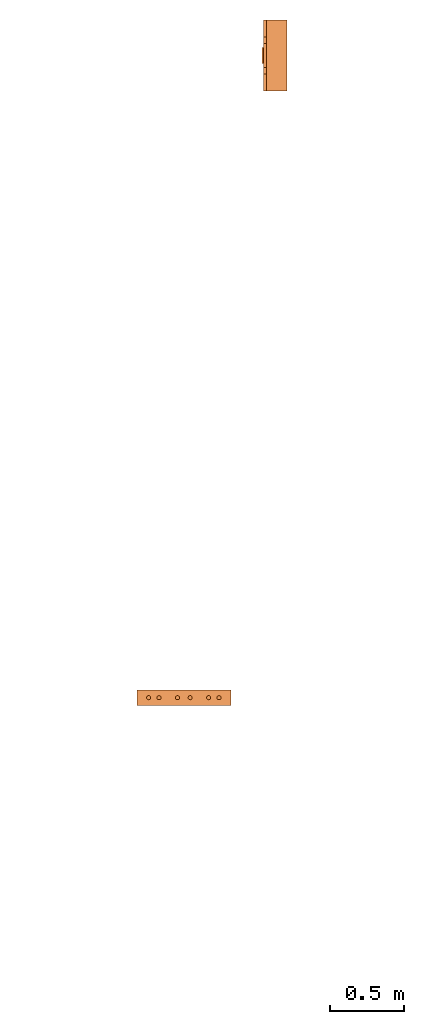
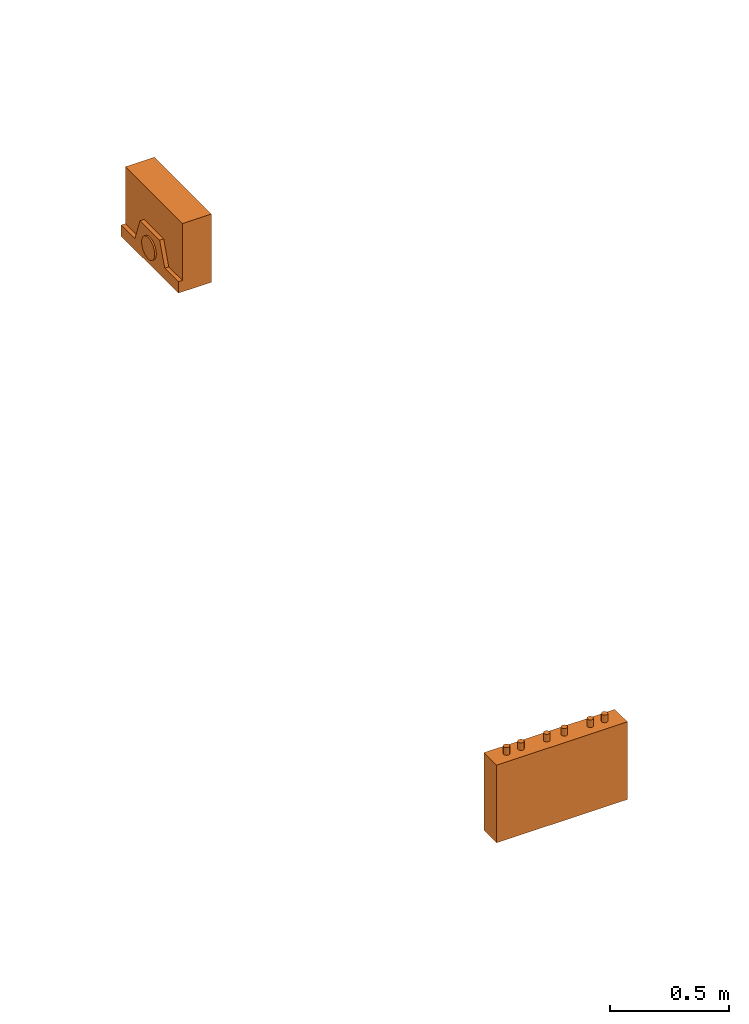
# One storey, part 3 of 4: 2 proxies.
"""IFC2X3 building model written with IfcOpenShell, lengths in millimetres."""

from ifc_helpers import new_model, entity, si_unit, converted_unit, derived_unit, direction, frame, origin, place, context, subcontext, project, spatial, faceted_brep, source, transform, mapped, material, material_list, type_object, type_shapes, element, save


model = new_model("IFC2X3")

# Units and contexts
model_context = context("Model", 3, precision=0.01, world=origin(), true_north=direction((6.12303176911189e-17, 1.0)))
body_context = subcontext(model_context, "Body", "Model", "MODEL_VIEW")
ifc_project = project(units=[si_unit("LENGTHUNIT", "METRE", prefix="MILLI"), si_unit("AREAUNIT", "SQUARE_METRE"), si_unit("VOLUMEUNIT", "CUBIC_METRE"), converted_unit("PLANEANGLEUNIT", "DEGREE", entity("IfcRatioMeasure", 0.0174532925199433), si_unit("PLANEANGLEUNIT", "RADIAN"), dimensions=[0, 0, 0, 0, 0, 0, 0]), si_unit("MASSUNIT", "GRAM", prefix="KILO"), derived_unit("MASSDENSITYUNIT", [(si_unit("MASSUNIT", "GRAM", prefix="KILO"), 1), (si_unit("LENGTHUNIT", "METRE"), -3)]), derived_unit("MOMENTOFINERTIAUNIT", [(si_unit("LENGTHUNIT", "METRE"), 4)]), si_unit("TIMEUNIT", "SECOND"), si_unit("FREQUENCYUNIT", "HERTZ"), si_unit("THERMODYNAMICTEMPERATUREUNIT", "DEGREE_CELSIUS"), derived_unit("THERMALTRANSMITTANCEUNIT", [(si_unit("MASSUNIT", "GRAM", prefix="KILO"), 1), (si_unit("THERMODYNAMICTEMPERATUREUNIT", "KELVIN"), -1), (si_unit("TIMEUNIT", "SECOND"), -3)]), derived_unit("VOLUMETRICFLOWRATEUNIT", [(si_unit("LENGTHUNIT", "METRE"), 3), (si_unit("TIMEUNIT", "SECOND"), -1)]), derived_unit("MASSFLOWRATEUNIT", [(si_unit("MASSUNIT", "GRAM", prefix="KILO"), 1), (si_unit("TIMEUNIT", "SECOND"), -1)]), derived_unit("ROTATIONALFREQUENCYUNIT", [(si_unit("TIMEUNIT", "SECOND"), -1)]), si_unit("ELECTRICCURRENTUNIT", "AMPERE"), si_unit("ELECTRICVOLTAGEUNIT", "VOLT"), si_unit("POWERUNIT", "WATT"), si_unit("FORCEUNIT", "NEWTON", prefix="KILO"), si_unit("ILLUMINANCEUNIT", "LUX"), si_unit("LUMINOUSFLUXUNIT", "LUMEN"), si_unit("LUMINOUSINTENSITYUNIT", "CANDELA"), derived_unit("USERDEFINED", [(si_unit("MASSUNIT", "GRAM", prefix="KILO"), -1), (si_unit("LENGTHUNIT", "METRE"), -2), (si_unit("TIMEUNIT", "SECOND"), 3), (si_unit("LUMINOUSFLUXUNIT", "LUMEN"), 1)]), derived_unit("LINEARVELOCITYUNIT", [(si_unit("LENGTHUNIT", "METRE"), 1), (si_unit("TIMEUNIT", "SECOND"), -1)]), si_unit("PRESSUREUNIT", "PASCAL"), derived_unit("USERDEFINED", [(si_unit("LENGTHUNIT", "METRE"), -2), (si_unit("MASSUNIT", "GRAM", prefix="KILO"), 1), (si_unit("TIMEUNIT", "SECOND"), -2)]), derived_unit("LINEARFORCEUNIT", [(si_unit("MASSUNIT", "GRAM", prefix="KILO"), 1), (si_unit("LENGTHUNIT", "METRE"), 1), (si_unit("TIMEUNIT", "SECOND"), -2), (si_unit("LENGTHUNIT", "METRE"), -1)]), derived_unit("PLANARFORCEUNIT", [(si_unit("MASSUNIT", "GRAM", prefix="KILO"), 1), (si_unit("LENGTHUNIT", "METRE"), 1), (si_unit("TIMEUNIT", "SECOND"), -2), (si_unit("LENGTHUNIT", "METRE"), -2)])], contexts=[model_context])

# Site, building, storey
site_placement = place(None, frame((0.0, 2493.83037508239, 0.0)))
site = spatial("IfcSite", under=ifc_project, at=site_placement, CompositionType="ELEMENT")
building_placement = place(site_placement, origin())
building = spatial("IfcBuilding", under=site, at=building_placement, CompositionType="ELEMENT")
storey_placement = place(building_placement, frame((0.0, 0.0, 15900.0)))
storey = spatial("IfcBuildingStorey", under=building, at=storey_placement, Name="05", CompositionType="ELEMENT", Elevation=15900.0)

# Proxies
ifc_material_1 = material()
ifc_material_2 = material()
ifc_material_list_1 = material_list([ifc_material_1, ifc_material_2])
building_element_proxy_type_1 = type_object("IfcBuildingElementProxyType", PredefinedType="NOTDEFINED", material=ifc_material_1)
shared_shape_1 = source(origin(), body_context, "Body", "Brep", [
    faceted_brep([(168.201612490282, 212.500000000001, 135.54049916809), (168.201612490282, 201.109127034741, 126.799974925206), (168.201612490282, 192.368602791857, 115.409101959946), (168.201612490282, 186.874079554102, 102.144149440585), (168.201612490282, 185.0, 87.9091019599461), (168.201612490282, 186.874079554102, 73.6740544793074), (168.201612490282, 192.368602791856, 60.4091019599461), (168.201612490282, 201.10912703474, 49.0182289946861), (168.201612490282, 212.500000000001, 40.2777047518019), (168.201612490282, 225.764952519362, 34.7831815140474), (168.201612490282, 240.0, 32.9091019599461), (168.201612490282, 254.235047480639, 34.7831815140472), (168.201612490282, 267.5, 40.2777047518019), (168.201612490282, 278.890872965261, 49.0182289946858), (168.201612490282, 287.631397208145, 60.4091019599458), (168.201612490282, 293.125920445899, 73.6740544793071), (168.201612490282, 295.0, 87.9091019599458), (168.201612490282, 293.125920445899, 102.144149440584), (168.201612490282, 287.631397208145, 115.409101959946), (168.201612490282, 278.890872965261, 126.799974925206), (168.201612490282, 267.500000000001, 135.54049916809), (168.201612490282, 254.235047480639, 141.035022405845), (168.201612490282, 240.0, 142.909101959946), (168.201612490282, 225.764952519362, 141.035022405845), (160.0, 225.764952519362, 34.7831815140474), (160.0, 212.500000000001, 40.2777047518019), (160.0, 201.10912703474, 49.0182289946861), (160.0, 192.368602791856, 60.4091019599461), (160.0, 186.874079554102, 73.6740544793074), (160.0, 185.0, 87.9091019599463), (160.0, 186.874079554102, 102.144149440585), (160.0, 192.368602791857, 115.409101959946), (160.0, 201.109127034741, 126.799974925206), (160.0, 212.500000000001, 135.54049916809), (160.0, 225.764952519362, 141.035022405845), (160.0, 240.0, 142.909101959946), (160.0, 254.235047480639, 141.035022405845), (160.0, 267.500000000001, 135.54049916809), (160.0, 278.890872965261, 126.799974925206), (160.0, 287.631397208145, 115.409101959946), (160.0, 293.125920445899, 102.144149440584), (160.0, 295.0, 87.9091019599458), (160.0, 293.125920445899, 73.6740544793071), (160.0, 287.631397208145, 60.4091019599458), (160.0, 278.890872965261, 49.0182289946858), (160.0, 267.5, 40.2777047518019), (160.0, 254.235047480639, 34.7831815140472), (160.0, 240.0, 32.9091019599461)], [[[0, 1, 2, 3, 4, 5, 6, 7, 8, 9, 10, 11, 12, 13, 14, 15, 16, 17, 18, 19, 20, 21, 22, 23]], [[24, 25, 26, 27, 28, 29, 30, 31, 32, 33, 34, 35, 36, 37, 38, 39, 40, 41, 42, 43, 44, 45, 46, 47]], [[40, 17, 16, 41]], [[39, 18, 17, 40]], [[20, 19, 38, 37]], [[39, 38, 19, 18]], [[21, 20, 37, 36]], [[22, 21, 36, 35]], [[34, 23, 22, 35]], [[33, 0, 23, 34]], [[2, 1, 32, 31]], [[33, 32, 1, 0]], [[3, 2, 31, 30]], [[4, 3, 30, 29]], [[28, 5, 4, 29]], [[27, 6, 5, 28]], [[8, 7, 26, 25]], [[27, 26, 7, 6]], [[9, 8, 25, 24]], [[10, 9, 24, 47]], [[46, 11, 10, 47]], [[45, 12, 11, 46]], [[14, 13, 44, 43]], [[45, 44, 13, 12]], [[15, 14, 43, 42]], [[16, 15, 42, 41]]]),
    faceted_brep([(160.0, 0.0, 0.0), (160.0, 480.0, 0.0), (160.0, 480.0, 58.2870579365997), (160.0, 365.0, 58.2870579366005), (160.0, 322.247482084292, 175.748635534839), (160.0, 157.75251791571, 175.748635534839), (160.0, 115.0, 58.2870579366), (160.0, 0.0, 58.2870579365997), (0.0, 480.0, 0.0), (0.0, 0.0, 0.0), (0.0, 0.0, 350.0), (0.0, 480.0, 350.0), (140.211167148102, 480.0, 350.0), (140.211167148102, 480.0, 58.2870579365997), (140.211167148102, 0.0, 350.0), (140.211167148102, 0.0, 58.2870579365997), (140.211167148102, 365.0, 58.2870579366), (140.211167148102, 115.0, 58.2870579366), (140.211167148102, 157.75251791571, 175.748635534839), (140.211167148102, 322.247482084292, 175.748635534839)], [[[0, 1, 2, 3, 4, 5, 6, 7]], [[8, 9, 10, 11]], [[8, 11, 12, 13, 2, 1]], [[11, 10, 14, 12]], [[10, 9, 0, 7, 15, 14]], [[1, 0, 9, 8]], [[16, 13, 12, 14, 15, 17, 18, 19]], [[13, 16, 3, 2]], [[17, 15, 7, 6]], [[18, 17, 6, 5]], [[19, 18, 5, 4]], [[16, 19, 4, 3]]]),
])
type_shapes(building_element_proxy_type_1, [shared_shape_1])
proxy_1_placement = place(storey_placement, frame((60320.108534949, 16006.7429169829, 1500.0), z_axis=(0.0, 0.0, 1.0), x_axis=(-1.0, 0.0, 0.0)))
element("IfcBuildingElementProxy", 1, at=proxy_1_placement, inside=storey, type_object=building_element_proxy_type_1, material=ifc_material_list_1, context=body_context, shape_type="MappedRepresentation", body=[
    mapped(shared_shape_1, transform((0.0, 0.0, 0.0), scale=1.0)),
])
ifc_material_3 = material()
ifc_material_list_2 = material_list([ifc_material_3, ifc_material_2])
building_element_proxy_type_2 = type_object("IfcBuildingElementProxyType", PredefinedType="NOTDEFINED", material=ifc_material_3)
shared_shape_2 = source(origin(), body_context, "Body", "Brep", [
    faceted_brep([(61.7366777047886, 89.258069163288, 398.0), (63.9615384211591, 86.3585742266764, 398.0), (65.3601443362239, 82.9820408581116, 398.0), (65.837182768177, 79.3585742266763, 398.0), (65.3601443362239, 75.735107595241, 398.0), (63.9615384211591, 72.3585742266763, 398.0), (61.7366777047886, 69.4590792900646, 398.0), (58.8371827681769, 67.2342185736942, 398.0), (55.4606493996122, 65.8356126586294, 398.0), (51.8371827681769, 65.3585742266764, 398.0), (48.2137161367416, 65.8356126586295, 398.0), (44.8371827681769, 67.2342185736943, 398.0), (41.9376878315653, 69.4590792900647, 398.0), (39.7128271151948, 72.3585742266764, 398.0), (38.31422120013, 75.7351075952411, 398.0), (37.837182768177, 79.3585742266764, 398.0), (38.31422120013, 82.9820408581117, 398.0), (39.7128271151949, 86.3585742266764, 398.0), (41.9376878315653, 89.258069163288, 398.0), (44.837182768177, 91.4829298796585, 398.0), (48.2137161367417, 92.8815357947233, 398.0), (51.837182768177, 93.3585742266764, 398.0), (55.4606493996123, 92.8815357947233, 398.0), (58.837182768177, 91.4829298796585, 398.0), (58.8371827681769, 67.2342185736942, 436.716690815491), (61.7366777047886, 69.4590792900646, 436.716690815491), (63.9615384211591, 72.3585742266763, 436.716690815491), (65.3601443362239, 75.735107595241, 436.716690815491), (65.837182768177, 79.3585742266764, 436.716690815491), (65.3601443362239, 82.9820408581116, 436.716690815491), (63.9615384211591, 86.3585742266764, 436.716690815491), (61.7366777047886, 89.258069163288, 436.716690815491), (58.837182768177, 91.4829298796585, 436.716690815491), (55.4606493996123, 92.8815357947233, 436.716690815491), (51.837182768177, 93.3585742266764, 436.716690815491), (48.2137161367417, 92.8815357947233, 436.716690815491), (44.837182768177, 91.4829298796585, 436.716690815491), (41.9376878315653, 89.258069163288, 436.716690815491), (39.7128271151949, 86.3585742266764, 436.716690815491), (38.31422120013, 82.9820408581117, 436.716690815491), (37.837182768177, 79.3585742266764, 436.716690815491), (38.31422120013, 75.7351075952411, 436.716690815491), (39.7128271151948, 72.3585742266764, 436.716690815491), (41.9376878315653, 69.4590792900647, 436.716690815491), (44.8371827681769, 67.2342185736943, 436.716690815491), (48.2137161367416, 65.8356126586295, 436.716690815491), (51.8371827681769, 65.3585742266764, 436.716690815491), (55.4606493996122, 65.8356126586294, 436.716690815491)], [[[0, 1, 2, 3, 4, 5, 6, 7, 8, 9, 10, 11, 12, 13, 14, 15, 16, 17, 18, 19, 20, 21, 22, 23]], [[24, 25, 26, 27, 28, 29, 30, 31, 32, 33, 34, 35, 36, 37, 38, 39, 40, 41, 42, 43, 44, 45, 46, 47]], [[40, 15, 14, 41]], [[13, 42, 41, 14]], [[43, 12, 11, 44]], [[13, 12, 43, 42]], [[44, 11, 10, 45]], [[9, 46, 45, 10]], [[47, 8, 7, 24]], [[6, 25, 24, 7]], [[26, 5, 4, 27]], [[6, 5, 26, 25]], [[27, 4, 3, 28]], [[47, 46, 9, 8]], [[1, 30, 29, 2]], [[0, 31, 30, 1]], [[22, 33, 32, 23]], [[23, 32, 31, 0]], [[21, 34, 33, 22]], [[28, 3, 2, 29]], [[35, 20, 19, 36]], [[18, 37, 36, 19]], [[38, 17, 16, 39]], [[18, 17, 38, 37]], [[39, 16, 15, 40]], [[35, 34, 21, 20]]]),
    faceted_brep([(58.837182768177, 542.517070120343, 436.716690815491), (61.7366777047886, 544.741930836713, 436.716690815491), (63.9615384211591, 547.641425773325, 436.716690815491), (65.360144336224, 551.017959141889, 436.716690815491), (65.837182768177, 554.641425773325, 436.716690815491), (65.360144336224, 558.26489240476, 436.716690815491), (63.9615384211592, 561.641425773325, 436.716690815491), (61.7366777047887, 564.540920709937, 436.716690815491), (58.8371827681771, 566.765781426307, 436.716690815491), (55.4606493996123, 568.164387341372, 436.716690815491), (51.8371827681771, 568.641425773325, 436.716690815491), (48.2137161367418, 568.164387341372, 436.716690815491), (44.8371827681771, 566.765781426307, 436.716690815491), (41.9376878315654, 564.540920709937, 436.716690815491), (39.7128271151949, 561.641425773325, 436.716690815491), (38.3142212001301, 558.26489240476, 436.716690815491), (37.837182768177, 554.641425773325, 436.716690815491), (38.3142212001301, 551.01795914189, 436.716690815491), (39.7128271151949, 547.641425773325, 436.716690815491), (41.9376878315653, 544.741930836713, 436.716690815491), (44.837182768177, 542.517070120343, 436.716690815491), (48.2137161367417, 541.118464205278, 436.716690815491), (51.837182768177, 540.641425773325, 436.716690815491), (55.4606493996123, 541.118464205278, 436.716690815491), (51.8371827681771, 568.641425773325, 398.0), (55.4606493996123, 568.164387341372, 398.0), (58.8371827681771, 566.765781426307, 398.0), (61.7366777047887, 564.540920709937, 398.0), (63.9615384211592, 561.641425773325, 398.0), (65.360144336224, 558.26489240476, 398.0), (65.837182768177, 554.641425773325, 398.0), (65.360144336224, 551.017959141889, 398.0), (63.9615384211591, 547.641425773325, 398.0), (61.7366777047886, 544.741930836713, 398.0), (58.837182768177, 542.517070120343, 398.0), (55.4606493996123, 541.118464205278, 398.0), (51.837182768177, 540.641425773325, 398.0), (48.2137161367417, 541.118464205278, 398.0), (44.837182768177, 542.517070120343, 398.0), (41.9376878315653, 544.741930836713, 398.0), (39.7128271151949, 547.641425773325, 398.0), (38.3142212001301, 551.01795914189, 398.0), (37.837182768177, 554.641425773325, 398.0), (38.3142212001301, 558.26489240476, 398.0), (39.7128271151949, 561.641425773325, 398.0), (41.9376878315654, 564.540920709937, 398.0), (44.8371827681771, 566.765781426307, 398.0), (48.2137161367418, 568.164387341372, 398.0)], [[[0, 1, 2, 3, 4, 5, 6, 7, 8, 9, 10, 11, 12, 13, 14, 15, 16, 17, 18, 19, 20, 21, 22, 23]], [[24, 25, 26, 27, 28, 29, 30, 31, 32, 33, 34, 35, 36, 37, 38, 39, 40, 41, 42, 43, 44, 45, 46, 47]], [[17, 41, 40, 18]], [[39, 19, 18, 40]], [[20, 38, 37, 21]], [[39, 38, 20, 19]], [[21, 37, 36, 22]], [[41, 17, 16, 42]], [[23, 35, 34, 0]], [[33, 1, 0, 34]], [[2, 32, 31, 3]], [[33, 32, 2, 1]], [[3, 31, 30, 4]], [[35, 23, 22, 36]], [[29, 5, 4, 30]], [[28, 6, 5, 29]], [[9, 25, 24, 10]], [[27, 7, 6, 28]], [[26, 8, 7, 27]], [[26, 25, 9, 8]], [[11, 47, 46, 12]], [[45, 13, 12, 46]], [[14, 44, 43, 15]], [[45, 44, 14, 13]], [[15, 43, 42, 16]], [[47, 11, 10, 24]]]),
    faceted_brep([(58.8371827681769, 472.517070120343, 436.716690815491), (61.7366777047886, 474.741930836713, 436.716690815491), (63.961538421159, 477.641425773325, 436.716690815491), (65.3601443362239, 481.017959141889, 436.716690815491), (65.8371827681769, 484.641425773325, 436.716690815491), (65.3601443362239, 488.26489240476, 436.716690815491), (63.9615384211591, 491.641425773325, 436.716690815491), (61.7366777047886, 494.540920709936, 436.716690815491), (58.837182768177, 496.765781426307, 436.716690815491), (55.4606493996123, 498.164387341372, 436.716690815491), (51.837182768177, 498.641425773325, 436.716690815491), (48.2137161367417, 498.164387341372, 436.716690815491), (44.837182768177, 496.765781426307, 436.716690815491), (41.9376878315653, 494.540920709937, 436.716690815491), (39.7128271151948, 491.641425773325, 436.716690815491), (38.31422120013, 488.26489240476, 436.716690815491), (37.837182768177, 484.641425773325, 436.716690815491), (38.31422120013, 481.01795914189, 436.716690815491), (39.7128271151948, 477.641425773325, 436.716690815491), (41.9376878315653, 474.741930836713, 436.716690815491), (44.8371827681769, 472.517070120343, 436.716690815491), (48.2137161367416, 471.118464205278, 436.716690815491), (51.8371827681769, 470.641425773325, 436.716690815491), (55.4606493996122, 471.118464205278, 436.716690815491), (51.837182768177, 498.641425773325, 398.0), (55.4606493996123, 498.164387341372, 398.0), (58.837182768177, 496.765781426307, 398.0), (61.7366777047886, 494.540920709936, 398.0), (63.9615384211591, 491.641425773325, 398.0), (65.3601443362239, 488.26489240476, 398.0), (65.8371827681769, 484.641425773325, 398.0), (65.3601443362239, 481.017959141889, 398.0), (63.961538421159, 477.641425773325, 398.0), (61.7366777047886, 474.741930836713, 398.0), (58.8371827681769, 472.517070120343, 398.0), (55.4606493996122, 471.118464205278, 398.0), (51.8371827681769, 470.641425773325, 398.0), (48.2137161367416, 471.118464205278, 398.0), (44.8371827681769, 472.517070120343, 398.0), (41.9376878315653, 474.741930836713, 398.0), (39.7128271151948, 477.641425773325, 398.0), (38.31422120013, 481.01795914189, 398.0), (37.837182768177, 484.641425773325, 398.0), (38.31422120013, 488.26489240476, 398.0), (39.7128271151948, 491.641425773325, 398.0), (41.9376878315653, 494.540920709937, 398.0), (44.837182768177, 496.765781426307, 398.0), (48.2137161367417, 498.164387341372, 398.0)], [[[0, 1, 2, 3, 4, 5, 6, 7, 8, 9, 10, 11, 12, 13, 14, 15, 16, 17, 18, 19, 20, 21, 22, 23]], [[24, 25, 26, 27, 28, 29, 30, 31, 32, 33, 34, 35, 36, 37, 38, 39, 40, 41, 42, 43, 44, 45, 46, 47]], [[16, 42, 41, 17]], [[40, 18, 17, 41]], [[19, 39, 38, 20]], [[40, 39, 19, 18]], [[20, 38, 37, 21]], [[36, 22, 21, 37]], [[23, 35, 34, 0]], [[33, 1, 0, 34]], [[2, 32, 31, 3]], [[33, 32, 2, 1]], [[3, 31, 30, 4]], [[23, 22, 36, 35]], [[28, 6, 5, 29]], [[27, 7, 6, 28]], [[25, 9, 8, 26]], [[26, 8, 7, 27]], [[24, 10, 9, 25]], [[4, 30, 29, 5]], [[11, 47, 46, 12]], [[45, 13, 12, 46]], [[14, 44, 43, 15]], [[45, 44, 14, 13]], [[15, 43, 42, 16]], [[11, 10, 24, 47]]]),
    faceted_brep([(58.8371827681766, 347.517070120343, 436.716690815491), (61.7366777047883, 349.741930836713, 436.716690815491), (63.9615384211588, 352.641425773325, 436.716690815491), (65.3601443362236, 356.017959141889, 436.716690815491), (65.8371827681767, 359.641425773325, 436.716690815491), (65.3601443362237, 363.26489240476, 436.716690815491), (63.9615384211589, 366.641425773325, 436.716690815491), (61.7366777047884, 369.540920709937, 436.716690815491), (58.8371827681767, 371.765781426307, 436.716690815491), (55.460649399612, 373.164387341372, 436.716690815491), (51.8371827681767, 373.641425773325, 436.716690815491), (48.2137161367414, 373.164387341372, 436.716690815491), (44.8371827681767, 371.765781426307, 436.716690815491), (41.9376878315651, 369.540920709937, 436.716690815491), (39.7128271151946, 366.641425773325, 436.716690815491), (38.3142212001298, 363.26489240476, 436.716690815491), (37.8371827681767, 359.641425773325, 436.716690815491), (38.3142212001298, 356.01795914189, 436.716690815491), (39.7128271151945, 352.641425773325, 436.716690815491), (41.937687831565, 349.741930836713, 436.716690815491), (44.8371827681767, 347.517070120343, 436.716690815491), (48.2137161367414, 346.118464205278, 436.716690815491), (51.8371827681766, 345.641425773325, 436.716690815491), (55.4606493996119, 346.118464205278, 436.716690815491), (51.8371827681767, 373.641425773325, 398.0), (55.460649399612, 373.164387341372, 398.0), (58.8371827681767, 371.765781426307, 398.0), (61.7366777047884, 369.540920709937, 398.0), (63.9615384211589, 366.641425773325, 398.0), (65.3601443362237, 363.26489240476, 398.0), (65.8371827681767, 359.641425773325, 398.0), (65.3601443362236, 356.017959141889, 398.0), (63.9615384211588, 352.641425773325, 398.0), (61.7366777047883, 349.741930836713, 398.0), (58.8371827681766, 347.517070120343, 398.0), (55.4606493996119, 346.118464205278, 398.0), (51.8371827681766, 345.641425773325, 398.0), (48.2137161367414, 346.118464205278, 398.0), (44.8371827681767, 347.517070120343, 398.0), (41.937687831565, 349.741930836713, 398.0), (39.7128271151945, 352.641425773325, 398.0), (38.3142212001298, 356.01795914189, 398.0), (37.8371827681767, 359.641425773325, 398.0), (38.3142212001298, 363.26489240476, 398.0), (39.7128271151946, 366.641425773325, 398.0), (41.9376878315651, 369.540920709937, 398.0), (44.8371827681767, 371.765781426307, 398.0), (48.2137161367414, 373.164387341372, 398.0)], [[[0, 1, 2, 3, 4, 5, 6, 7, 8, 9, 10, 11, 12, 13, 14, 15, 16, 17, 18, 19, 20, 21, 22, 23]], [[24, 25, 26, 27, 28, 29, 30, 31, 32, 33, 34, 35, 36, 37, 38, 39, 40, 41, 42, 43, 44, 45, 46, 47]], [[16, 42, 41, 17]], [[40, 18, 17, 41]], [[19, 39, 38, 20]], [[40, 39, 19, 18]], [[20, 38, 37, 21]], [[36, 22, 21, 37]], [[23, 35, 34, 0]], [[33, 1, 0, 34]], [[2, 32, 31, 3]], [[33, 32, 2, 1]], [[3, 31, 30, 4]], [[23, 22, 36, 35]], [[28, 6, 5, 29]], [[27, 7, 6, 28]], [[25, 9, 8, 26]], [[26, 8, 7, 27]], [[24, 10, 9, 25]], [[4, 30, 29, 5]], [[11, 47, 46, 12]], [[45, 13, 12, 46]], [[14, 44, 43, 15]], [[45, 44, 14, 13]], [[15, 43, 42, 16]], [[11, 10, 24, 47]]]),
    faceted_brep([(58.8371827681766, 262.234218573694, 436.716690815491), (61.7366777047883, 264.459079290065, 436.716690815491), (63.9615384211588, 267.358574226676, 436.716690815491), (65.3601443362236, 270.735107595241, 436.716690815491), (65.8371827681767, 274.358574226676, 436.716690815491), (65.3601443362237, 277.982040858112, 436.716690815491), (63.9615384211588, 281.358574226676, 436.716690815491), (61.7366777047884, 284.258069163288, 436.716690815491), (58.8371827681767, 286.482929879658, 436.716690815491), (55.460649399612, 287.881535794723, 436.716690815491), (51.8371827681767, 288.358574226676, 436.716690815491), (48.2137161367414, 287.881535794723, 436.716690815491), (44.8371827681767, 286.482929879659, 436.716690815491), (41.9376878315651, 284.258069163288, 436.716690815491), (39.7128271151946, 281.358574226676, 436.716690815491), (38.3142212001298, 277.982040858112, 436.716690815491), (37.8371827681767, 274.358574226676, 436.716690815491), (38.3142212001297, 270.735107595241, 436.716690815491), (39.7128271151945, 267.358574226676, 436.716690815491), (41.937687831565, 264.459079290065, 436.716690815491), (44.8371827681767, 262.234218573694, 436.716690815491), (48.2137161367414, 260.835612658629, 436.716690815491), (51.8371827681766, 260.358574226676, 436.716690815491), (55.4606493996119, 260.835612658629, 436.716690815491), (51.8371827681767, 288.358574226676, 398.0), (55.460649399612, 287.881535794723, 398.0), (58.8371827681767, 286.482929879658, 398.0), (61.7366777047884, 284.258069163288, 398.0), (63.9615384211588, 281.358574226676, 398.0), (65.3601443362237, 277.982040858112, 398.0), (65.8371827681767, 274.358574226676, 398.0), (65.3601443362236, 270.735107595241, 398.0), (63.9615384211588, 267.358574226676, 398.0), (61.7366777047883, 264.459079290065, 398.0), (58.8371827681766, 262.234218573694, 398.0), (55.4606493996119, 260.835612658629, 398.0), (51.8371827681766, 260.358574226676, 398.0), (48.2137161367414, 260.835612658629, 398.0), (44.8371827681767, 262.234218573694, 398.0), (41.937687831565, 264.459079290065, 398.0), (39.7128271151945, 267.358574226676, 398.0), (38.3142212001297, 270.735107595241, 398.0), (37.8371827681767, 274.358574226676, 398.0), (38.3142212001298, 277.982040858112, 398.0), (39.7128271151946, 281.358574226676, 398.0), (41.9376878315651, 284.258069163288, 398.0), (44.8371827681767, 286.482929879659, 398.0), (48.2137161367414, 287.881535794723, 398.0)], [[[0, 1, 2, 3, 4, 5, 6, 7, 8, 9, 10, 11, 12, 13, 14, 15, 16, 17, 18, 19, 20, 21, 22, 23]], [[24, 25, 26, 27, 28, 29, 30, 31, 32, 33, 34, 35, 36, 37, 38, 39, 40, 41, 42, 43, 44, 45, 46, 47]], [[16, 42, 41, 17]], [[40, 18, 17, 41]], [[19, 39, 38, 20]], [[40, 39, 19, 18]], [[20, 38, 37, 21]], [[36, 22, 21, 37]], [[23, 35, 34, 0]], [[33, 1, 0, 34]], [[2, 32, 31, 3]], [[33, 32, 2, 1]], [[3, 31, 30, 4]], [[23, 22, 36, 35]], [[4, 30, 29, 5]], [[28, 6, 5, 29]], [[7, 27, 26, 8]], [[28, 27, 7, 6]], [[8, 26, 25, 9]], [[24, 10, 9, 25]], [[11, 47, 46, 12]], [[45, 13, 12, 46]], [[14, 44, 43, 15]], [[45, 44, 14, 13]], [[15, 43, 42, 16]], [[11, 10, 24, 47]]]),
    faceted_brep([(58.8371827681768, 137.234218573694, 436.716690815491), (61.7366777047885, 139.459079290065, 436.716690815491), (63.961538421159, 142.358574226676, 436.716690815491), (65.3601443362238, 145.735107595241, 436.716690815491), (65.8371827681769, 149.358574226676, 436.716690815491), (65.3601443362239, 152.982040858112, 436.716690815491), (63.961538421159, 156.358574226676, 436.716690815491), (61.7366777047886, 159.258069163288, 436.716690815491), (58.8371827681769, 161.482929879659, 436.716690815491), (55.4606493996122, 162.881535794723, 436.716690815491), (51.8371827681769, 163.358574226676, 436.716690815491), (48.2137161367416, 162.881535794723, 436.716690815491), (44.8371827681769, 161.482929879659, 436.716690815491), (41.9376878315653, 159.258069163288, 436.716690815491), (39.7128271151948, 156.358574226676, 436.716690815491), (38.31422120013, 152.982040858112, 436.716690815491), (37.8371827681769, 149.358574226676, 436.716690815491), (38.3142212001299, 145.735107595241, 436.716690815491), (39.7128271151947, 142.358574226676, 436.716690815491), (41.9376878315652, 139.459079290065, 436.716690815491), (44.8371827681769, 137.234218573694, 436.716690815491), (48.2137161367416, 135.83561265863, 436.716690815491), (51.8371827681768, 135.358574226676, 436.716690815491), (55.4606493996121, 135.835612658629, 436.716690815491), (61.7366777047886, 159.258069163288, 398.0), (63.961538421159, 156.358574226676, 398.0), (65.3601443362239, 152.982040858112, 398.0), (65.8371827681769, 149.358574226676, 398.0), (65.3601443362238, 145.735107595241, 398.0), (63.961538421159, 142.358574226676, 398.0), (61.7366777047885, 139.459079290065, 398.0), (58.8371827681768, 137.234218573694, 398.0), (55.4606493996121, 135.835612658629, 398.0), (51.8371827681768, 135.358574226676, 398.0), (48.2137161367416, 135.83561265863, 398.0), (44.8371827681769, 137.234218573694, 398.0), (41.9376878315652, 139.459079290065, 398.0), (39.7128271151947, 142.358574226676, 398.0), (38.3142212001299, 145.735107595241, 398.0), (37.8371827681769, 149.358574226676, 398.0), (38.31422120013, 152.982040858112, 398.0), (39.7128271151948, 156.358574226676, 398.0), (41.9376878315653, 159.258069163288, 398.0), (44.8371827681769, 161.482929879659, 398.0), (48.2137161367416, 162.881535794723, 398.0), (51.8371827681769, 163.358574226676, 398.0), (55.4606493996122, 162.881535794723, 398.0), (58.8371827681769, 161.482929879659, 398.0)], [[[0, 1, 2, 3, 4, 5, 6, 7, 8, 9, 10, 11, 12, 13, 14, 15, 16, 17, 18, 19, 20, 21, 22, 23]], [[24, 25, 26, 27, 28, 29, 30, 31, 32, 33, 34, 35, 36, 37, 38, 39, 40, 41, 42, 43, 44, 45, 46, 47]], [[16, 39, 38, 17]], [[37, 18, 17, 38]], [[19, 36, 35, 20]], [[37, 36, 19, 18]], [[20, 35, 34, 21]], [[33, 22, 21, 34]], [[23, 32, 31, 0]], [[30, 1, 0, 31]], [[2, 29, 28, 3]], [[30, 29, 2, 1]], [[3, 28, 27, 4]], [[23, 22, 33, 32]], [[25, 6, 5, 26]], [[24, 7, 6, 25]], [[46, 9, 8, 47]], [[47, 8, 7, 24]], [[45, 10, 9, 46]], [[4, 27, 26, 5]], [[11, 44, 43, 12]], [[42, 13, 12, 43]], [[14, 41, 40, 15]], [[42, 41, 14, 13]], [[15, 40, 39, 16]], [[11, 10, 45, 44]]]),
    faceted_brep([(106.0, 0.0, 0.0), (106.0, 634.0, 0.0), (106.0, 634.0, 398.0), (106.0, 0.0, 398.0), (0.0, 634.0, 398.0), (0.0, 524.500000000001, 254.822902819641), (0.0, 518.470476127564, 257.320413382257), (0.0, 529.677669529664, 250.849937254693), (0.0, 512.0, 258.17226772503), (0.0, 122.0, 258.17226772503), (0.0, 533.650635094612, 245.672267725029), (0.0, 536.148145657227, 239.642743852593), (0.0, 537.0, 233.17226772503), (0.0, 634.0, 0.0), (0.0, 0.0, 398.0), (0.0, 537.0, 143.17226772503), (0.0, 536.148145657227, 136.701791597467), (0.0, 533.650635094611, 130.67226772503), (0.0, 529.677669529664, 125.494598195366), (0.0, 524.5, 121.521632630419), (0.0, 518.470476127563, 119.024122067803), (0.0, 512.0, 118.17226772503), (0.0, 122.0, 118.172267725031), (0.0, 0.0, 0.0), (0.0, 97.0, 233.17226772503), (0.0, 115.529523872437, 119.024122067805), (0.0, 109.5, 121.521632630421), (0.0, 104.322330470337, 125.494598195368), (0.0, 100.349364905389, 130.672267725032), (0.0, 97.8518543427736, 136.701791597469), (0.0, 97.0, 143.172267725033), (0.0, 97.8518543427739, 239.642743852593), (0.0, 115.529523872438, 257.320413382257), (0.0, 109.500000000001, 254.822902819641), (0.0, 104.322330470337, 250.849937254693), (0.0, 100.34936490539, 245.67226772503), (16.2395209800454, 533.650635094612, 245.672267725029), (16.2395209800454, 536.148145657227, 239.642743852593), (16.2395209800454, 537.0, 233.17226772503), (16.2395209800454, 537.0, 143.17226772503), (16.2395209800454, 536.148145657227, 136.701791597467), (16.2395209800454, 533.650635094611, 130.67226772503), (16.2395209800454, 529.677669529664, 125.494598195366), (16.2395209800454, 524.5, 121.521632630419), (16.2395209800454, 518.470476127563, 119.024122067803), (16.2395209800454, 512.0, 118.17226772503), (16.2395209800454, 122.0, 118.172267725032), (16.2395209800454, 115.529523872437, 119.024122067805), (16.2395209800454, 109.5, 121.521632630421), (16.2395209800454, 104.322330470337, 125.494598195368), (16.2395209800454, 100.349364905389, 130.672267725032), (16.2395209800454, 97.8518543427736, 136.701791597469), (16.2395209800454, 97.0, 143.172267725032), (16.2395209800454, 97.0, 233.17226772503), (16.2395209800454, 97.8518543427739, 239.642743852593), (16.2395209800454, 100.34936490539, 245.67226772503), (16.2395209800454, 104.322330470337, 250.849937254694), (16.2395209800454, 109.500000000001, 254.822902819641), (16.2395209800454, 115.529523872438, 257.320413382257), (16.2395209800454, 122.0, 258.17226772503), (16.2395209800454, 512.0, 258.17226772503), (16.2395209800454, 518.470476127564, 257.320413382257), (16.2395209800454, 524.500000000001, 254.822902819641), (16.2395209800454, 529.677669529664, 250.849937254693)], [[[0, 1, 2, 3]], [[4, 5, 6]], [[5, 4, 7]], [[6, 8, 4]], [[4, 8, 9]], [[10, 7, 4]], [[11, 10, 4]], [[12, 11, 4]], [[4, 13, 12]], [[9, 14, 4]], [[15, 12, 13]], [[16, 15, 13]], [[16, 13, 17]], [[18, 17, 13]], [[13, 19, 18]], [[19, 13, 20]], [[21, 20, 13]], [[13, 22, 21]], [[22, 13, 23]], [[14, 24, 23]], [[25, 22, 23]], [[23, 26, 25]], [[26, 23, 27]], [[28, 27, 23]], [[28, 23, 29]], [[30, 29, 23]], [[30, 23, 24]], [[31, 24, 14]], [[9, 32, 14]], [[33, 14, 32]], [[14, 33, 34]], [[34, 35, 14]], [[35, 31, 14]], [[2, 1, 13, 4]], [[3, 2, 4, 14]], [[0, 3, 14, 23]], [[1, 0, 23, 13]], [[36, 37, 38, 39, 40, 41, 42, 43, 44, 45, 46, 47, 48, 49, 50, 51, 52, 53, 54, 55, 56, 57, 58, 59, 60, 61, 62, 63]], [[9, 8, 60, 59]], [[32, 9, 59, 58]], [[33, 32, 58, 57]], [[33, 57, 56, 34]], [[35, 34, 56, 55]], [[31, 35, 55, 54]], [[31, 54, 53, 24]], [[24, 53, 52, 30]], [[29, 30, 52, 51]], [[28, 29, 51, 50]], [[28, 50, 49, 27]], [[26, 27, 49, 48]], [[25, 26, 48, 47]], [[25, 47, 46, 22]], [[22, 46, 45, 21]], [[20, 21, 45, 44]], [[19, 20, 44, 43]], [[19, 43, 42, 18]], [[17, 18, 42, 41]], [[16, 17, 41, 40]], [[16, 40, 39, 15]], [[15, 39, 38, 12]], [[11, 12, 38, 37]], [[10, 11, 37, 36]], [[10, 36, 63, 7]], [[5, 7, 63, 62]], [[6, 5, 62, 61]], [[6, 61, 60, 8]]]),
])
type_shapes(building_element_proxy_type_2, [shared_shape_2])
proxy_2_placement = place(storey_placement, frame((59305.4167535516, 11481.1696249176, 1500.0), z_axis=(0.0, 0.0, 1.0), x_axis=(0.0, -1.0, 0.0)))
element("IfcBuildingElementProxy", 2, at=proxy_2_placement, inside=storey, type_object=building_element_proxy_type_2, material=ifc_material_list_2, context=body_context, shape_type="MappedRepresentation", body=[
    mapped(shared_shape_2, transform((0.0, 0.0, 0.0), scale=1.0)),
])

save(model, "model.ifc")
